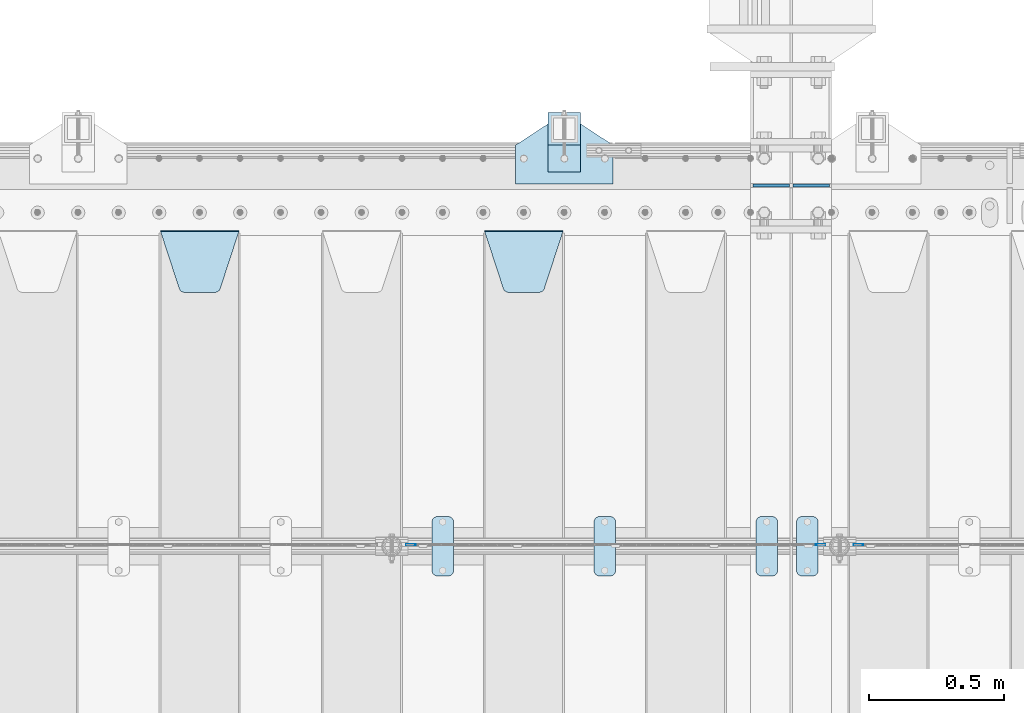
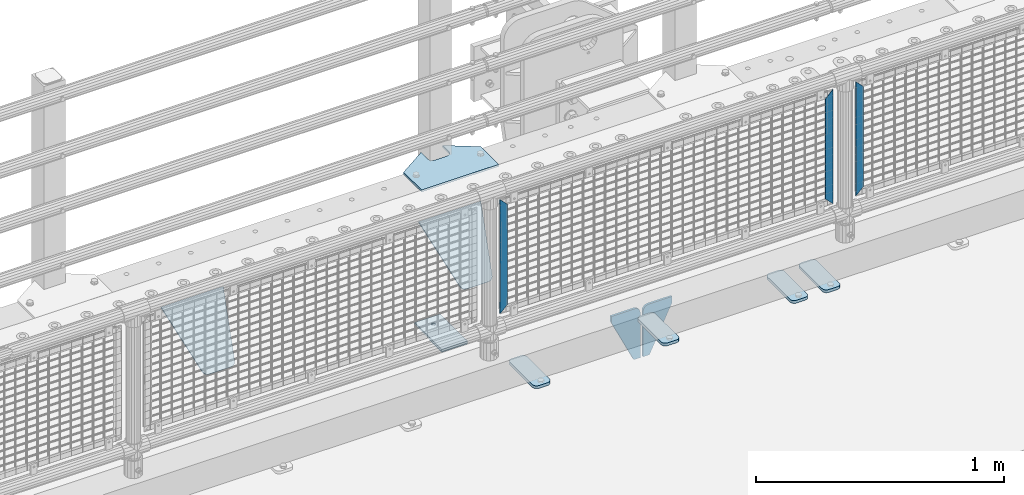
# One storey, part 199 of 219: 14 plates.
"""IFC2X3 building model written with IfcOpenShell, lengths in millimetres."""

from ifc_helpers import new_model, si_unit, frame, origin_with_axes, place, context, subcontext, project, spatial, faceted_brep, material, type_object, element, save


model = new_model("IFC2X3")

# Units and contexts
model_context = context("Model", 3, precision=1e-05, world=origin_with_axes())
body_context = subcontext(model_context, "Body", "Model", "MODEL_VIEW")
ifc_project = project(units=[si_unit("LENGTHUNIT", "METRE", prefix="MILLI"), si_unit("AREAUNIT", "SQUARE_METRE"), si_unit("VOLUMEUNIT", "CUBIC_METRE"), si_unit("MASSUNIT", "GRAM", prefix="KILO"), si_unit("TIMEUNIT", "SECOND"), si_unit("PLANEANGLEUNIT", "RADIAN"), si_unit("SOLIDANGLEUNIT", "STERADIAN"), si_unit("THERMODYNAMICTEMPERATUREUNIT", "DEGREE_CELSIUS"), si_unit("LUMINOUSINTENSITYUNIT", "LUMEN")], contexts=[model_context])

# Site, building, storey
site_placement = place(None, origin_with_axes())
site = spatial("IfcSite", under=ifc_project, at=site_placement, CompositionType="ELEMENT")
building_placement = place(site_placement, origin_with_axes())
building = spatial("IfcBuilding", under=site, at=building_placement, Name="Standard", CompositionType="ELEMENT")
storey_placement = place(building_placement, origin_with_axes())
storey = spatial("IfcBuildingStorey", under=building, at=storey_placement, Name="Undefined", CompositionType="ELEMENT", Elevation=0.0)

# Plates
ifc_material_1 = material(Name="STEEL/S355N")
plate_type_1 = type_object("IfcPlateType", PredefinedType="NOTDEFINED")
for number, where, z_axis, x_axis in (
    (1, (10383.5000000179, 33000.0000000149, -915.000018206195), (0.0, 0.0, -1.0), (-1.0, 0.0, 0.0)),
    (2, (10396.500000018, 33000.0000000149, -915.000018206195), (0.0, 0.0, -1.0), (1.0, 0.0, 0.0)),
):
    element("IfcPlate", number, at=place(storey_placement, frame(where, z_axis=z_axis, x_axis=x_axis)), inside=storey, type_object=plate_type_1, material=ifc_material_1, context=body_context, shape_type="Brep", body=[
        faceted_brep([(0.0, -5.0, 27.0), (0.0, -5.0, 250.0), (0.0, 5.0, 250.0), (0.0, 5.0, 27.0), (30.0, -5.0, 250.0), (30.0, 5.0, 250.0), (135.0, -5.0, 30.0), (135.0, 5.0, 30.0), (135.0, -5.0, 0.0), (135.0, 5.0, 0.0), (27.0, -5.0, 0.0), (27.0, 5.0, 0.0), (22.3114992029932, -5.0, 0.410190668670339), (22.3114992029932, 5.0, 0.410190668670339), (17.7654561302061, -5.0, 1.62829923878041), (17.7654561302061, 5.0, 1.62829923878041), (13.5, -5.0, 3.61731409782021), (13.5, 5.0, 3.61731409782021), (9.64473453846404, -5.0, 6.31680003578765), (9.64473453846404, 5.0, 6.31680003578765), (6.31680003578731, -5.0, 9.64473453846347), (6.31680003578731, 5.0, 9.64473453846347), (3.61731409782078, -5.0, 13.5), (3.61731409782078, 5.0, 13.5), (1.62829923878053, -5.0, 17.765456130207), (1.62829923878053, 5.0, 17.765456130207), (0.410190668670111, -5.0, 22.3114992029929), (0.410190668670111, 5.0, 22.3114992029929)], [[[0, 1, 2, 3]], [[1, 4, 5, 2]], [[4, 6, 7, 5]], [[6, 8, 9, 7]], [[8, 10, 11, 9]], [[10, 12, 13, 11]], [[12, 14, 15, 13]], [[14, 16, 17, 15]], [[16, 18, 19, 17]], [[18, 20, 21, 19]], [[20, 22, 23, 21]], [[22, 24, 25, 23]], [[24, 26, 27, 25]], [[26, 0, 3, 27]], [[5, 7, 9, 11, 13, 15, 17, 19, 21, 23, 25, 27, 3, 2]], [[26, 24, 22, 20, 18, 16, 14, 12, 10, 8, 6, 4, 1, 0]]]),
    ])
plate_type_2 = type_object("IfcPlateType", PredefinedType="NOTDEFINED")
plate_1_placement = place(storey_placement, frame((9255.0, 32831.767766956, -1.76776695296758), z_axis=(0.0, -0.707106781186547, -0.707106781186548), x_axis=(1.0, 0.0, 0.0)))
element("IfcPlate", 3, at=plate_1_placement, inside=storey, type_object=plate_type_2, material=ifc_material_1, context=body_context, shape_type="Brep", body=[
    faceted_brep([(0.0, -2.5, 0.0), (69.345504679477, -2.5, 300.171731424834), (69.345504679477, 2.49999999999636, 300.171731424831), (0.0, 2.5, 0.0), (70.9274061199576, -2.50000000000364, 304.8974424154), (70.9274061199576, 2.49999999999636, 304.8974424154), (73.3818627772307, -2.50000000000364, 309.234538108532), (73.3818627772307, 2.49999999999636, 309.234538108532), (76.6187032999569, -2.50000000000364, 313.023683126106), (76.6187032999569, 2.49999999999636, 313.023683126106), (80.5190132704993, -2.50000000000364, 316.125672595372), (80.5190132704993, 2.49999999999636, 316.125672595372), (84.9395038596831, -2.50000000000364, 318.426546230476), (84.9395038596831, 2.5, 318.426546230479), (89.7177759439237, -2.50000000000364, 319.841774983277), (89.7177759439237, 2.5, 319.841774983281), (94.6782862926502, -2.50000000000364, 320.319366455078), (94.6782862926502, 2.49999999999636, 320.319366455078), (195.32171370735, -2.50000000000364, 320.319366455078), (195.32171370735, 2.49999999999636, 320.319366455078), (200.282224056076, -2.50000000000364, 319.841774983277), (200.282224056076, 2.5, 319.841774983281), (205.060496140317, -2.50000000000364, 318.426546230476), (205.060496140317, 2.49999999999636, 318.426546230476), (209.480986729501, -2.50000000000364, 316.125672595372), (209.480986729501, 2.49999999999636, 316.125672595372), (213.381296700043, -2.50000000000364, 313.023683126106), (213.381296700043, 2.49999999999272, 313.023683126106), (216.618137222769, -2.50000000000364, 309.234538108529), (216.618137222769, 2.49999999999636, 309.234538108525), (219.072593880042, -2.50000000000364, 304.8974424154), (219.072593880042, 2.49999999999636, 304.8974424154), (220.654495320523, -2.5, 300.171731424834), (220.654495320523, 2.49999999999636, 300.171731424831), (290.0, -2.50000000000364, 3.63797880709171e-12), (290.0, 2.49999999999636, 0.0)], [[[0, 1, 2, 3]], [[1, 4, 5, 2]], [[4, 6, 7, 5]], [[6, 8, 9, 7]], [[8, 10, 11, 9]], [[10, 12, 13, 11]], [[12, 14, 15, 13]], [[14, 16, 17, 15]], [[16, 18, 19, 17]], [[18, 20, 21, 19]], [[20, 22, 23, 21]], [[22, 24, 25, 23]], [[24, 26, 27, 25]], [[26, 28, 29, 27]], [[28, 30, 31, 29]], [[30, 32, 33, 31]], [[32, 34, 35, 33]], [[34, 0, 3, 35]], [[5, 7, 9, 11, 13, 15, 17, 19, 21, 23, 25, 27, 29, 31, 33, 35, 3, 2]], [[34, 32, 30, 28, 26, 24, 22, 20, 18, 16, 14, 12, 10, 8, 6, 4, 1, 0]]]),
])
plate_2_placement = place(storey_placement, frame((8055.0, 32831.767766956, -1.76776695296758), z_axis=(0.0, -0.707106781186547, -0.707106781186548), x_axis=(1.0, 0.0, 0.0)))
element("IfcPlate", 4, at=plate_2_placement, inside=storey, type_object=plate_type_2, material=ifc_material_1, context=body_context, shape_type="Brep", body=[
    faceted_brep([(0.0, -2.5, 0.0), (69.345504679477, -2.5, 300.171731424834), (69.345504679477, 2.49999999999636, 300.171731424831), (0.0, 2.5, 0.0), (70.9274061199576, -2.50000000000364, 304.8974424154), (70.9274061199576, 2.49999999999636, 304.8974424154), (73.3818627772307, -2.50000000000364, 309.234538108532), (73.3818627772307, 2.49999999999636, 309.234538108532), (76.6187032999569, -2.50000000000364, 313.023683126106), (76.6187032999569, 2.49999999999636, 313.023683126106), (80.5190132704993, -2.50000000000364, 316.125672595372), (80.5190132704993, 2.49999999999636, 316.125672595372), (84.9395038596831, -2.50000000000364, 318.426546230476), (84.9395038596831, 2.5, 318.426546230479), (89.7177759439237, -2.50000000000364, 319.841774983277), (89.7177759439237, 2.5, 319.841774983281), (94.6782862926502, -2.50000000000364, 320.319366455078), (94.6782862926502, 2.49999999999636, 320.319366455078), (195.32171370735, -2.50000000000364, 320.319366455078), (195.32171370735, 2.49999999999636, 320.319366455078), (200.282224056076, -2.50000000000364, 319.841774983277), (200.282224056076, 2.5, 319.841774983281), (205.060496140317, -2.50000000000364, 318.426546230476), (205.060496140317, 2.49999999999636, 318.426546230476), (209.480986729501, -2.50000000000364, 316.125672595372), (209.480986729501, 2.49999999999636, 316.125672595372), (213.381296700043, -2.50000000000364, 313.023683126106), (213.381296700043, 2.49999999999272, 313.023683126106), (216.618137222769, -2.50000000000364, 309.234538108529), (216.618137222769, 2.49999999999636, 309.234538108525), (219.072593880042, -2.50000000000364, 304.8974424154), (219.072593880042, 2.49999999999636, 304.8974424154), (220.654495320523, -2.5, 300.171731424834), (220.654495320523, 2.49999999999636, 300.171731424831), (290.0, -2.50000000000364, 3.63797880709171e-12), (290.0, 2.49999999999636, 0.0)], [[[0, 1, 2, 3]], [[1, 4, 5, 2]], [[4, 6, 7, 5]], [[6, 8, 9, 7]], [[8, 10, 11, 9]], [[10, 12, 13, 11]], [[12, 14, 15, 13]], [[14, 16, 17, 15]], [[16, 18, 19, 17]], [[18, 20, 21, 19]], [[20, 22, 23, 21]], [[22, 24, 25, 23]], [[24, 26, 27, 25]], [[26, 28, 29, 27]], [[28, 30, 31, 29]], [[30, 32, 33, 31]], [[32, 34, 35, 33]], [[34, 0, 3, 35]], [[5, 7, 9, 11, 13, 15, 17, 19, 21, 23, 25, 27, 29, 31, 33, 35, 3, 2]], [[34, 32, 30, 28, 26, 24, 22, 20, 18, 16, 14, 12, 10, 8, 6, 4, 1, 0]]]),
])
ifc_material_2 = material(Name="Misc_Undefined")
plate_type_3 = type_object("IfcPlateType", PredefinedType="NOTDEFINED")
for number, where, z_axis, x_axis in (
    (5, (10657.509713541, 31670.5, 879.519963133601), (-0.707008801899319, 0.0, -0.707204746899291), (-0.707204746899285, 0.0, 0.707008801899324)),
    (6, (8999.50971354097, 31670.5, 879.519963133601), (-0.707008801899319, 0.0, -0.707204746899291), (-0.707204746899285, 0.0, 0.707008801899324)),
):
    element("IfcPlate", number, at=place(storey_placement, frame(where, z_axis=z_axis, x_axis=x_axis)), inside=storey, type_object=plate_type_3, material=ifc_material_2, context=body_context, shape_type="Brep", body=[
        faceted_brep([(0.0, -1.5, -5.6843418860808e-14), (-348.552185058593, -1.5, 348.655029296875), (-348.552185058593, 1.5, 348.655029296875), (0.0, 1.5, -5.6843418860808e-14), (-348.544891357421, -1.5, 398.152496337892), (-348.544891357421, 1.5, 398.152496337892), (49.5043945312482, -1.5, 7.6397554948926e-11), (49.5043945312482, 1.5, 7.6397554948926e-11)], [[[0, 1, 2, 3]], [[1, 4, 5, 2]], [[4, 6, 7, 5]], [[6, 0, 3, 7]], [[5, 7, 3, 2]], [[6, 4, 1, 0]]]),
    ])
plate_3_placement = place(storey_placement, frame((10480.4996874836, 31670.5, 879.52), z_axis=(0.707103624179499, 0.0, -0.707109938179501), x_axis=(0.707109938179499, 0.0, 0.707103624179502)))
element("IfcPlate", 7, at=plate_3_placement, inside=storey, type_object=plate_type_3, material=ifc_material_2, context=body_context, shape_type="Brep", body=[
    faceted_brep([(0.0, -1.5, -5.6843418860808e-14), (-348.605163574219, -1.5, 348.602081298829), (-348.605163574219, 1.5, 348.602081298829), (0.0, 1.5, -5.6843418860808e-14), (-348.605163574217, -1.5, 398.0993347168), (-348.605163574217, 1.5, 398.0993347168), (49.4976959228516, -1.5, -1.0550138540566e-10), (49.4976959228516, 1.5, -1.0550138540566e-10)], [[[0, 1, 2, 3]], [[1, 4, 5, 2]], [[4, 6, 7, 5]], [[6, 0, 3, 7]], [[5, 7, 3, 2]], [[6, 4, 1, 0]]]),
])
ifc_material_3 = material(Name="STEEL/S355J2")
plate_type_4 = type_object("IfcPlateType", PredefinedType="NOTDEFINED")
plate_4_placement = place(storey_placement, frame((10260.0, 31774.5, 21.0199999999977), z_axis=(1.0, 0.0, 0.0), x_axis=(0.0, -1.0, 0.0)))
element("IfcPlate", 8, at=plate_4_placement, inside=storey, type_object=plate_type_4, material=ifc_material_3, context=body_context, shape_type="Brep", body=[
    faceted_brep([(0.0, -7.0, 20.0), (0.0, -7.0, 60.0), (0.0, 7.0, 60.0), (0.0, 7.0, 20.0), (0.384294391937146, -7.0, 63.9018064403226), (0.384294391937146, 7.0, 63.9018064403226), (1.52240934977453, -7.0, 67.6536686473009), (1.52240934977453, 7.0, 67.6536686473009), (3.37060775395003, -7.0, 71.1114046603925), (3.37060775395003, 7.0, 71.1114046603925), (5.8578643762703, -7.0, 74.1421356237315), (5.8578643762703, 7.0, 74.1421356237315), (8.88859533960931, -7.0, 76.6293922460518), (8.88859533960931, 7.0, 76.6293922460518), (12.3463313526991, -7.0, 78.4775906502255), (12.3463313526991, 7.0, 78.4775906502255), (16.0981935596792, -7.0, 79.6157056080647), (16.0981935596792, 7.0, 79.6157056080647), (20.0, -7.0, 80.0), (20.0, 7.0, 80.0), (200.0, -7.0, 80.0), (200.0, 7.0, 80.0), (203.901806440321, -7.0, 79.6157056080647), (203.901806440321, 7.0, 79.6157056080647), (207.653668647301, -7.0, 78.4775906502255), (207.653668647301, 7.0, 78.4775906502255), (211.111404660391, -7.0, 76.6293922460518), (211.111404660391, 7.0, 76.6293922460518), (214.14213562373, -7.0, 74.1421356237315), (214.14213562373, 7.0, 74.1421356237315), (216.62939224605, -7.0, 71.1114046603925), (216.62939224605, 7.0, 71.1114046603925), (218.477590650225, -7.0, 67.6536686473009), (218.477590650225, 7.0, 67.6536686473009), (219.615705608063, -7.0, 63.9018064403226), (219.615705608063, 7.0, 63.9018064403226), (220.0, -7.0, 60.0), (220.0, 7.0, 60.0), (220.0, -7.0, 20.0), (220.0, 7.0, 20.0), (219.615705608063, -7.0, 16.0981935596774), (219.615705608063, 7.0, 16.0981935596774), (218.477590650225, -7.0, 12.3463313526991), (218.477590650225, 7.0, 12.3463313526991), (216.62939224605, -7.0, 8.88859533960749), (216.62939224605, 7.0, 8.88859533960749), (214.14213562373, -7.0, 5.85786437626848), (214.14213562373, 7.0, 5.85786437626848), (211.111404660391, -7.0, 3.37060775394821), (211.111404660391, 7.0, 3.37060775394821), (207.653668647301, -7.0, 1.52240934977453), (207.653668647301, 7.0, 1.52240934977453), (203.901806440321, -7.0, 0.384294391935327), (203.901806440321, 7.0, 0.384294391935327), (200.0, -7.0, 0.0), (200.0, 7.0, 0.0), (20.0, -7.0, 0.0), (20.0, 7.0, 0.0), (16.0981935596792, -7.0, 0.384294391935327), (16.0981935596792, 7.0, 0.384294391935327), (12.3463313526991, -7.0, 1.52240934977453), (12.3463313526991, 7.0, 1.52240934977453), (8.88859533960931, -7.0, 3.37060775394821), (8.88859533960931, 7.0, 3.37060775394821), (5.8578643762703, -7.0, 5.85786437626848), (5.8578643762703, 7.0, 5.85786437626848), (3.37060775395003, -7.0, 8.88859533960749), (3.37060775395003, 7.0, 8.88859533960749), (1.52240934977453, -7.0, 12.3463313526991), (1.52240934977453, 7.0, 12.3463313526991), (0.384294391937146, -7.0, 16.0981935596774), (0.384294391937146, 7.0, 16.0981935596774)], [[[0, 1, 2, 3]], [[1, 4, 5, 2]], [[4, 6, 7, 5]], [[6, 8, 9, 7]], [[8, 10, 11, 9]], [[10, 12, 13, 11]], [[12, 14, 15, 13]], [[14, 16, 17, 15]], [[16, 18, 19, 17]], [[18, 20, 21, 19]], [[20, 22, 23, 21]], [[22, 24, 25, 23]], [[24, 26, 27, 25]], [[26, 28, 29, 27]], [[28, 30, 31, 29]], [[30, 32, 33, 31]], [[32, 34, 35, 33]], [[34, 36, 37, 35]], [[36, 38, 39, 37]], [[38, 40, 41, 39]], [[40, 42, 43, 41]], [[42, 44, 45, 43]], [[44, 46, 47, 45]], [[46, 48, 49, 47]], [[48, 50, 51, 49]], [[50, 52, 53, 51]], [[52, 54, 55, 53]], [[54, 56, 57, 55]], [[56, 58, 59, 57]], [[58, 60, 61, 59]], [[60, 62, 63, 61]], [[62, 64, 65, 63]], [[64, 66, 67, 65]], [[66, 68, 69, 67]], [[68, 70, 71, 69]], [[70, 0, 3, 71]], [[5, 7, 9, 11, 13, 15, 17, 19, 21, 23, 25, 27, 29, 31, 33, 35, 37, 39, 41, 43, 45, 47, 49, 51, 53, 55, 57, 59, 61, 63, 65, 67, 69, 71, 3, 2]], [[70, 68, 66, 64, 62, 60, 58, 56, 54, 52, 50, 48, 46, 44, 42, 40, 38, 36, 34, 32, 30, 28, 26, 24, 22, 20, 18, 16, 14, 12, 10, 8, 6, 4, 1, 0]]]),
])
plate_5_placement = place(storey_placement, frame((10410.0, 31774.5, 21.0199999999977), z_axis=(1.0, 0.0, 0.0), x_axis=(0.0, -1.0, 0.0)))
element("IfcPlate", 9, at=plate_5_placement, inside=storey, type_object=plate_type_4, material=ifc_material_3, context=body_context, shape_type="Brep", body=[
    faceted_brep([(0.0, -7.0, 20.0), (0.0, -7.0, 60.0), (0.0, 7.0, 60.0), (0.0, 7.0, 20.0), (0.384294391937146, -7.0, 63.9018064403226), (0.384294391937146, 7.0, 63.9018064403226), (1.52240934977453, -7.0, 67.6536686473009), (1.52240934977453, 7.0, 67.6536686473009), (3.37060775395003, -7.0, 71.1114046603925), (3.37060775395003, 7.0, 71.1114046603925), (5.8578643762703, -7.0, 74.1421356237315), (5.8578643762703, 7.0, 74.1421356237315), (8.88859533960931, -7.0, 76.6293922460518), (8.88859533960931, 7.0, 76.6293922460518), (12.3463313526991, -7.0, 78.4775906502255), (12.3463313526991, 7.0, 78.4775906502255), (16.0981935596792, -7.0, 79.6157056080647), (16.0981935596792, 7.0, 79.6157056080647), (20.0, -7.0, 80.0), (20.0, 7.0, 80.0), (200.0, -7.0, 80.0), (200.0, 7.0, 80.0), (203.901806440321, -7.0, 79.6157056080647), (203.901806440321, 7.0, 79.6157056080647), (207.653668647301, -7.0, 78.4775906502255), (207.653668647301, 7.0, 78.4775906502255), (211.111404660391, -7.0, 76.6293922460518), (211.111404660391, 7.0, 76.6293922460518), (214.14213562373, -7.0, 74.1421356237315), (214.14213562373, 7.0, 74.1421356237315), (216.62939224605, -7.0, 71.1114046603925), (216.62939224605, 7.0, 71.1114046603925), (218.477590650225, -7.0, 67.6536686473009), (218.477590650225, 7.0, 67.6536686473009), (219.615705608063, -7.0, 63.9018064403226), (219.615705608063, 7.0, 63.9018064403226), (220.0, -7.0, 60.0), (220.0, 7.0, 60.0), (220.0, -7.0, 20.0), (220.0, 7.0, 20.0), (219.615705608063, -7.0, 16.0981935596774), (219.615705608063, 7.0, 16.0981935596774), (218.477590650225, -7.0, 12.3463313526991), (218.477590650225, 7.0, 12.3463313526991), (216.62939224605, -7.0, 8.88859533960749), (216.62939224605, 7.0, 8.88859533960749), (214.14213562373, -7.0, 5.85786437626848), (214.14213562373, 7.0, 5.85786437626848), (211.111404660391, -7.0, 3.37060775394821), (211.111404660391, 7.0, 3.37060775394821), (207.653668647301, -7.0, 1.52240934977453), (207.653668647301, 7.0, 1.52240934977453), (203.901806440321, -7.0, 0.384294391935327), (203.901806440321, 7.0, 0.384294391935327), (200.0, -7.0, 0.0), (200.0, 7.0, 0.0), (20.0, -7.0, 0.0), (20.0, 7.0, 0.0), (16.0981935596792, -7.0, 0.384294391935327), (16.0981935596792, 7.0, 0.384294391935327), (12.3463313526991, -7.0, 1.52240934977453), (12.3463313526991, 7.0, 1.52240934977453), (8.88859533960931, -7.0, 3.37060775394821), (8.88859533960931, 7.0, 3.37060775394821), (5.8578643762703, -7.0, 5.85786437626848), (5.8578643762703, 7.0, 5.85786437626848), (3.37060775395003, -7.0, 8.88859533960749), (3.37060775395003, 7.0, 8.88859533960749), (1.52240934977453, -7.0, 12.3463313526991), (1.52240934977453, 7.0, 12.3463313526991), (0.384294391937146, -7.0, 16.0981935596774), (0.384294391937146, 7.0, 16.0981935596774)], [[[0, 1, 2, 3]], [[1, 4, 5, 2]], [[4, 6, 7, 5]], [[6, 8, 9, 7]], [[8, 10, 11, 9]], [[10, 12, 13, 11]], [[12, 14, 15, 13]], [[14, 16, 17, 15]], [[16, 18, 19, 17]], [[18, 20, 21, 19]], [[20, 22, 23, 21]], [[22, 24, 25, 23]], [[24, 26, 27, 25]], [[26, 28, 29, 27]], [[28, 30, 31, 29]], [[30, 32, 33, 31]], [[32, 34, 35, 33]], [[34, 36, 37, 35]], [[36, 38, 39, 37]], [[38, 40, 41, 39]], [[40, 42, 43, 41]], [[42, 44, 45, 43]], [[44, 46, 47, 45]], [[46, 48, 49, 47]], [[48, 50, 51, 49]], [[50, 52, 53, 51]], [[52, 54, 55, 53]], [[54, 56, 57, 55]], [[56, 58, 59, 57]], [[58, 60, 61, 59]], [[60, 62, 63, 61]], [[62, 64, 65, 63]], [[64, 66, 67, 65]], [[66, 68, 69, 67]], [[68, 70, 71, 69]], [[70, 0, 3, 71]], [[5, 7, 9, 11, 13, 15, 17, 19, 21, 23, 25, 27, 29, 31, 33, 35, 37, 39, 41, 43, 45, 47, 49, 51, 53, 55, 57, 59, 61, 63, 65, 67, 69, 71, 3, 2]], [[70, 68, 66, 64, 62, 60, 58, 56, 54, 52, 50, 48, 46, 44, 42, 40, 38, 36, 34, 32, 30, 28, 26, 24, 22, 20, 18, 16, 14, 12, 10, 8, 6, 4, 1, 0]]]),
])
plate_6_placement = place(storey_placement, frame((9660.0, 31774.5, 21.0199999999977), z_axis=(1.0, 0.0, 0.0), x_axis=(0.0, -1.0, 0.0)))
element("IfcPlate", 10, at=plate_6_placement, inside=storey, type_object=plate_type_4, material=ifc_material_3, context=body_context, shape_type="Brep", body=[
    faceted_brep([(0.0, -7.0, 20.0), (0.0, -7.0, 60.0), (0.0, 7.0, 60.0), (0.0, 7.0, 20.0), (0.384294391937146, -7.0, 63.9018064403226), (0.384294391937146, 7.0, 63.9018064403226), (1.52240934977453, -7.0, 67.6536686473009), (1.52240934977453, 7.0, 67.6536686473009), (3.37060775395003, -7.0, 71.1114046603925), (3.37060775395003, 7.0, 71.1114046603925), (5.8578643762703, -7.0, 74.1421356237315), (5.8578643762703, 7.0, 74.1421356237315), (8.88859533960931, -7.0, 76.6293922460518), (8.88859533960931, 7.0, 76.6293922460518), (12.3463313526991, -7.0, 78.4775906502255), (12.3463313526991, 7.0, 78.4775906502255), (16.0981935596792, -7.0, 79.6157056080647), (16.0981935596792, 7.0, 79.6157056080647), (20.0, -7.0, 80.0), (20.0, 7.0, 80.0), (200.0, -7.0, 80.0), (200.0, 7.0, 80.0), (203.901806440321, -7.0, 79.6157056080647), (203.901806440321, 7.0, 79.6157056080647), (207.653668647301, -7.0, 78.4775906502255), (207.653668647301, 7.0, 78.4775906502255), (211.111404660391, -7.0, 76.6293922460518), (211.111404660391, 7.0, 76.6293922460518), (214.14213562373, -7.0, 74.1421356237315), (214.14213562373, 7.0, 74.1421356237315), (216.62939224605, -7.0, 71.1114046603925), (216.62939224605, 7.0, 71.1114046603925), (218.477590650225, -7.0, 67.6536686473009), (218.477590650225, 7.0, 67.6536686473009), (219.615705608063, -7.0, 63.9018064403226), (219.615705608063, 7.0, 63.9018064403226), (220.0, -7.0, 60.0), (220.0, 7.0, 60.0), (220.0, -7.0, 20.0), (220.0, 7.0, 20.0), (219.615705608063, -7.0, 16.0981935596774), (219.615705608063, 7.0, 16.0981935596774), (218.477590650225, -7.0, 12.3463313526991), (218.477590650225, 7.0, 12.3463313526991), (216.62939224605, -7.0, 8.88859533960749), (216.62939224605, 7.0, 8.88859533960749), (214.14213562373, -7.0, 5.85786437626848), (214.14213562373, 7.0, 5.85786437626848), (211.111404660391, -7.0, 3.37060775394821), (211.111404660391, 7.0, 3.37060775394821), (207.653668647301, -7.0, 1.52240934977453), (207.653668647301, 7.0, 1.52240934977453), (203.901806440321, -7.0, 0.384294391935327), (203.901806440321, 7.0, 0.384294391935327), (200.0, -7.0, 0.0), (200.0, 7.0, 0.0), (20.0, -7.0, 0.0), (20.0, 7.0, 0.0), (16.0981935596792, -7.0, 0.384294391935327), (16.0981935596792, 7.0, 0.384294391935327), (12.3463313526991, -7.0, 1.52240934977453), (12.3463313526991, 7.0, 1.52240934977453), (8.88859533960931, -7.0, 3.37060775394821), (8.88859533960931, 7.0, 3.37060775394821), (5.8578643762703, -7.0, 5.85786437626848), (5.8578643762703, 7.0, 5.85786437626848), (3.37060775395003, -7.0, 8.88859533960749), (3.37060775395003, 7.0, 8.88859533960749), (1.52240934977453, -7.0, 12.3463313526991), (1.52240934977453, 7.0, 12.3463313526991), (0.384294391937146, -7.0, 16.0981935596774), (0.384294391937146, 7.0, 16.0981935596774)], [[[0, 1, 2, 3]], [[1, 4, 5, 2]], [[4, 6, 7, 5]], [[6, 8, 9, 7]], [[8, 10, 11, 9]], [[10, 12, 13, 11]], [[12, 14, 15, 13]], [[14, 16, 17, 15]], [[16, 18, 19, 17]], [[18, 20, 21, 19]], [[20, 22, 23, 21]], [[22, 24, 25, 23]], [[24, 26, 27, 25]], [[26, 28, 29, 27]], [[28, 30, 31, 29]], [[30, 32, 33, 31]], [[32, 34, 35, 33]], [[34, 36, 37, 35]], [[36, 38, 39, 37]], [[38, 40, 41, 39]], [[40, 42, 43, 41]], [[42, 44, 45, 43]], [[44, 46, 47, 45]], [[46, 48, 49, 47]], [[48, 50, 51, 49]], [[50, 52, 53, 51]], [[52, 54, 55, 53]], [[54, 56, 57, 55]], [[56, 58, 59, 57]], [[58, 60, 61, 59]], [[60, 62, 63, 61]], [[62, 64, 65, 63]], [[64, 66, 67, 65]], [[66, 68, 69, 67]], [[68, 70, 71, 69]], [[70, 0, 3, 71]], [[5, 7, 9, 11, 13, 15, 17, 19, 21, 23, 25, 27, 29, 31, 33, 35, 37, 39, 41, 43, 45, 47, 49, 51, 53, 55, 57, 59, 61, 63, 65, 67, 69, 71, 3, 2]], [[70, 68, 66, 64, 62, 60, 58, 56, 54, 52, 50, 48, 46, 44, 42, 40, 38, 36, 34, 32, 30, 28, 26, 24, 22, 20, 18, 16, 14, 12, 10, 8, 6, 4, 1, 0]]]),
])
plate_7_placement = place(storey_placement, frame((9060.0, 31774.5, 21.0199999999977), z_axis=(1.0, 0.0, 0.0), x_axis=(0.0, -1.0, 0.0)))
element("IfcPlate", 11, at=plate_7_placement, inside=storey, type_object=plate_type_4, material=ifc_material_3, context=body_context, shape_type="Brep", body=[
    faceted_brep([(0.0, -7.0, 20.0), (0.0, -7.0, 60.0), (0.0, 7.0, 60.0), (0.0, 7.0, 20.0), (0.384294391937146, -7.0, 63.9018064403226), (0.384294391937146, 7.0, 63.9018064403226), (1.52240934977453, -7.0, 67.6536686473009), (1.52240934977453, 7.0, 67.6536686473009), (3.37060775395003, -7.0, 71.1114046603925), (3.37060775395003, 7.0, 71.1114046603925), (5.8578643762703, -7.0, 74.1421356237315), (5.8578643762703, 7.0, 74.1421356237315), (8.88859533960931, -7.0, 76.6293922460518), (8.88859533960931, 7.0, 76.6293922460518), (12.3463313526991, -7.0, 78.4775906502255), (12.3463313526991, 7.0, 78.4775906502255), (16.0981935596792, -7.0, 79.6157056080647), (16.0981935596792, 7.0, 79.6157056080647), (20.0, -7.0, 80.0), (20.0, 7.0, 80.0), (200.0, -7.0, 80.0), (200.0, 7.0, 80.0), (203.901806440321, -7.0, 79.6157056080647), (203.901806440321, 7.0, 79.6157056080647), (207.653668647301, -7.0, 78.4775906502255), (207.653668647301, 7.0, 78.4775906502255), (211.111404660391, -7.0, 76.6293922460518), (211.111404660391, 7.0, 76.6293922460518), (214.14213562373, -7.0, 74.1421356237315), (214.14213562373, 7.0, 74.1421356237315), (216.62939224605, -7.0, 71.1114046603925), (216.62939224605, 7.0, 71.1114046603925), (218.477590650225, -7.0, 67.6536686473009), (218.477590650225, 7.0, 67.6536686473009), (219.615705608063, -7.0, 63.9018064403226), (219.615705608063, 7.0, 63.9018064403226), (220.0, -7.0, 60.0), (220.0, 7.0, 60.0), (220.0, -7.0, 20.0), (220.0, 7.0, 20.0), (219.615705608063, -7.0, 16.0981935596774), (219.615705608063, 7.0, 16.0981935596774), (218.477590650225, -7.0, 12.3463313526991), (218.477590650225, 7.0, 12.3463313526991), (216.62939224605, -7.0, 8.88859533960749), (216.62939224605, 7.0, 8.88859533960749), (214.14213562373, -7.0, 5.85786437626848), (214.14213562373, 7.0, 5.85786437626848), (211.111404660391, -7.0, 3.37060775394821), (211.111404660391, 7.0, 3.37060775394821), (207.653668647301, -7.0, 1.52240934977453), (207.653668647301, 7.0, 1.52240934977453), (203.901806440321, -7.0, 0.384294391935327), (203.901806440321, 7.0, 0.384294391935327), (200.0, -7.0, 0.0), (200.0, 7.0, 0.0), (20.0, -7.0, 0.0), (20.0, 7.0, 0.0), (16.0981935596792, -7.0, 0.384294391935327), (16.0981935596792, 7.0, 0.384294391935327), (12.3463313526991, -7.0, 1.52240934977453), (12.3463313526991, 7.0, 1.52240934977453), (8.88859533960931, -7.0, 3.37060775394821), (8.88859533960931, 7.0, 3.37060775394821), (5.8578643762703, -7.0, 5.85786437626848), (5.8578643762703, 7.0, 5.85786437626848), (3.37060775395003, -7.0, 8.88859533960749), (3.37060775395003, 7.0, 8.88859533960749), (1.52240934977453, -7.0, 12.3463313526991), (1.52240934977453, 7.0, 12.3463313526991), (0.384294391937146, -7.0, 16.0981935596774), (0.384294391937146, 7.0, 16.0981935596774)], [[[0, 1, 2, 3]], [[1, 4, 5, 2]], [[4, 6, 7, 5]], [[6, 8, 9, 7]], [[8, 10, 11, 9]], [[10, 12, 13, 11]], [[12, 14, 15, 13]], [[14, 16, 17, 15]], [[16, 18, 19, 17]], [[18, 20, 21, 19]], [[20, 22, 23, 21]], [[22, 24, 25, 23]], [[24, 26, 27, 25]], [[26, 28, 29, 27]], [[28, 30, 31, 29]], [[30, 32, 33, 31]], [[32, 34, 35, 33]], [[34, 36, 37, 35]], [[36, 38, 39, 37]], [[38, 40, 41, 39]], [[40, 42, 43, 41]], [[42, 44, 45, 43]], [[44, 46, 47, 45]], [[46, 48, 49, 47]], [[48, 50, 51, 49]], [[50, 52, 53, 51]], [[52, 54, 55, 53]], [[54, 56, 57, 55]], [[56, 58, 59, 57]], [[58, 60, 61, 59]], [[60, 62, 63, 61]], [[62, 64, 65, 63]], [[64, 66, 67, 65]], [[66, 68, 69, 67]], [[68, 70, 71, 69]], [[70, 0, 3, 71]], [[5, 7, 9, 11, 13, 15, 17, 19, 21, 23, 25, 27, 29, 31, 33, 35, 37, 39, 41, 43, 45, 47, 49, 51, 53, 55, 57, 59, 61, 63, 65, 67, 69, 71, 3, 2]], [[70, 68, 66, 64, 62, 60, 58, 56, 54, 52, 50, 48, 46, 44, 42, 40, 38, 36, 34, 32, 30, 28, 26, 24, 22, 20, 18, 16, 14, 12, 10, 8, 6, 4, 1, 0]]]),
])
plate_type_5 = type_object("IfcPlateType", PredefinedType="NOTDEFINED")
plate_8_placement = place(storey_placement, frame((9370.0, 33005.0, 5.00000000004911), z_axis=(0.0, 1.0, 0.0), x_axis=(1.0, 0.0, 0.0)))
element("IfcPlate", 12, at=plate_8_placement, inside=storey, type_object=plate_type_5, material=ifc_material_3, context=body_context, shape_type="Brep", body=[
    faceted_brep([(0.0, -5.0, 0.0), (2.31396552408114e-06, -5.0, 145.0), (2.31396552408114e-06, 5.0, 145.0), (0.0, 5.0, 0.0), (130.0, -5.0, 230.0), (130.0, 5.0, 230.0), (130.0, -5.0, 180.0), (130.0, 5.0, 180.0), (130.48036798992, -5.0, 175.122741949599), (130.48036798992, 5.0, 175.122741949599), (131.903011687218, -5.0, 170.432914190875), (131.903011687218, 5.0, 170.432914190875), (134.213259692437, -5.0, 166.110744174512), (134.213259692437, 5.0, 166.110744174512), (137.322330470337, -5.0, 162.322330470335), (137.322330470337, 5.0, 162.322330470335), (141.11074417451, -5.0, 159.213259692435), (141.11074417451, 5.0, 159.213259692435), (145.432914190873, -5.0, 156.903011687216), (145.432914190873, 5.0, 156.903011687216), (150.122741949597, -5.0, 155.48036798992), (150.122741949597, 5.0, 155.48036798992), (155.0, -5.0, 155.0), (155.0, 5.0, 155.0), (205.0, -5.0, 155.0), (205.0, 5.0, 155.0), (209.877258050403, -5.0, 155.48036798992), (209.877258050403, 5.0, 155.48036798992), (214.567085809127, -5.0, 156.903011687216), (214.567085809127, 5.0, 156.903011687216), (218.88925582549, -5.0, 159.213259692435), (218.88925582549, 5.0, 159.213259692435), (222.677669529663, -5.0, 162.322330470335), (222.677669529663, 5.0, 162.322330470335), (225.786740307563, -5.0, 166.110744174512), (225.786740307563, 5.0, 166.110744174512), (228.096988312782, -5.0, 170.432914190875), (228.096988312782, 5.0, 170.432914190875), (229.51963201008, -5.0, 175.122741949599), (229.51963201008, 5.0, 175.122741949599), (230.0, -5.0, 180.0), (230.0, 5.0, 180.0), (230.0, -5.0, 230.0), (230.0, 5.0, 230.0), (360.0, -5.0, 145.0), (360.0, 5.0, 145.0), (360.0, -5.0, -7.27595761418343e-12), (360.0, 5.0, -7.27595761418343e-12)], [[[0, 1, 2, 3]], [[1, 4, 5, 2]], [[4, 6, 7, 5]], [[6, 8, 9, 7]], [[8, 10, 11, 9]], [[10, 12, 13, 11]], [[12, 14, 15, 13]], [[14, 16, 17, 15]], [[16, 18, 19, 17]], [[18, 20, 21, 19]], [[20, 22, 23, 21]], [[22, 24, 25, 23]], [[24, 26, 27, 25]], [[26, 28, 29, 27]], [[28, 30, 31, 29]], [[30, 32, 33, 31]], [[32, 34, 35, 33]], [[34, 36, 37, 35]], [[36, 38, 39, 37]], [[38, 40, 41, 39]], [[40, 42, 43, 41]], [[42, 44, 45, 43]], [[44, 46, 47, 45]], [[46, 0, 3, 47]], [[5, 7, 9, 11, 13, 15, 17, 19, 21, 23, 25, 27, 29, 31, 33, 35, 37, 39, 41, 43, 45, 47, 3, 2]], [[46, 44, 42, 40, 38, 36, 34, 32, 30, 28, 26, 24, 22, 20, 18, 16, 14, 12, 10, 8, 6, 4, 1, 0]]]),
])
plate_type_6 = type_object("IfcPlateType", PredefinedType="NOTDEFINED")
plate_9_placement = place(storey_placement, frame((9490.00000000014, 33050.0000000002, -850.000000000002), z_axis=(0.0, 1.0, 0.0), x_axis=(1.0, 0.0, 0.0)))
element("IfcPlate", 13, at=plate_9_placement, inside=storey, type_object=plate_type_6, material=ifc_material_3, context=body_context, shape_type="Brep", body=[
    faceted_brep([(66.3639610305399, -5.0, 163.636038969111), (66.3639610305399, 5.0, 163.636038969111), (59.9999999998618, 5.0, 160.999999999789), (59.9999999998618, -5.0, 160.999999999789), (53.6360389691836, 5.0, 163.636038969111), (53.6360389691836, -5.0, 163.636038969111), (50.9999999998618, 5.0, 169.999999999789), (50.9999999998618, -5.0, 169.999999999789), (53.6360389691836, 5.0, 176.363961030467), (53.6360389691836, -5.0, 176.363961030467), (59.9999999998618, 5.0, 178.999999999789), (59.9999999998618, -5.0, 178.999999999789), (66.3639610305399, 5.0, 176.363961030467), (66.3639610305399, -5.0, 176.363961030467), (68.9999999998618, 5.0, 169.999999999789), (68.9999999998618, -5.0, 169.999999999789), (120.0, -5.0, 0.0), (120.0, -5.0, 220.0), (0.0, -5.0, 220.0), (0.0, -5.0, 0.0), (0.0, 5.0, 0.0), (120.0, 5.0, 0.0), (120.0, 5.0, 220.0), (0.0, 5.0, 220.0)], [[[0, 1, 2, 3]], [[3, 2, 4, 5]], [[5, 4, 6, 7]], [[7, 6, 8, 9]], [[9, 8, 10, 11]], [[11, 10, 12, 13]], [[13, 12, 14, 15]], [[15, 14, 1, 0]], [[16, 17, 18, 19], [3, 5, 7, 9, 11, 13, 15, 0]], [[16, 19, 20, 21]], [[17, 16, 21, 22]], [[18, 17, 22, 23]], [[19, 18, 23, 20]], [[22, 21, 20, 23], [10, 8, 6, 4, 2, 1, 14, 12]]]),
])
plate_type_7 = type_object("IfcPlateType", PredefinedType="NOTDEFINED")
plate_10_placement = place(storey_placement, frame((9490.00000000014, 33050.0000000002, -857.500000000002), z_axis=(0.0, 1.0, 0.0), x_axis=(1.0, 0.0, 0.0)))
element("IfcPlate", 14, at=plate_10_placement, inside=storey, type_object=plate_type_7, material=ifc_material_3, context=body_context, shape_type="Brep", body=[
    faceted_brep([(0.0, -2.5, 0.0), (0.0, -2.5, 100.0), (0.0, 2.5, 100.0), (0.0, 2.5, 0.0), (120.0, -2.5, 100.0), (120.0, 2.5, 100.0), (120.0, -2.5, 0.0), (120.0, 2.5, 0.0)], [[[0, 1, 2, 3]], [[1, 4, 5, 2]], [[4, 6, 7, 5]], [[6, 0, 3, 7]], [[5, 7, 3, 2]], [[6, 4, 1, 0]]]),
])

save(model, "model.ifc")
